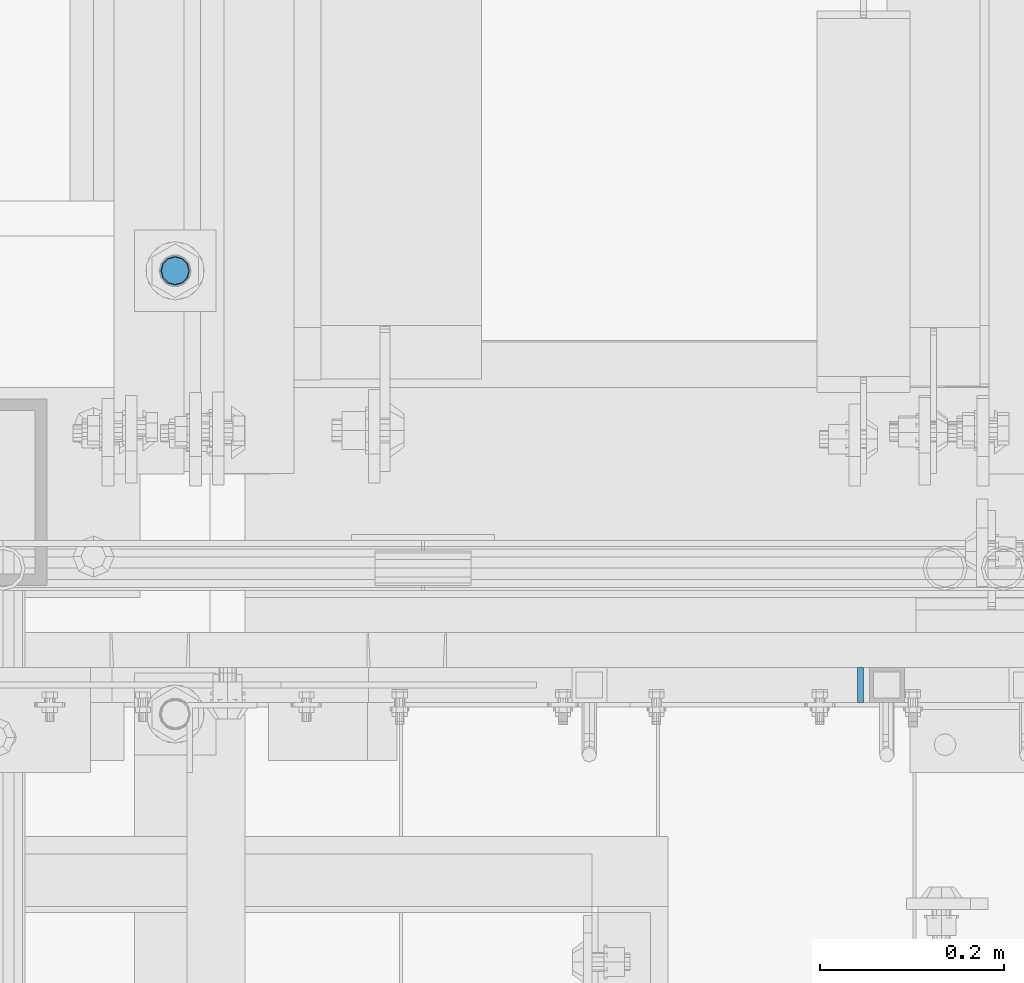
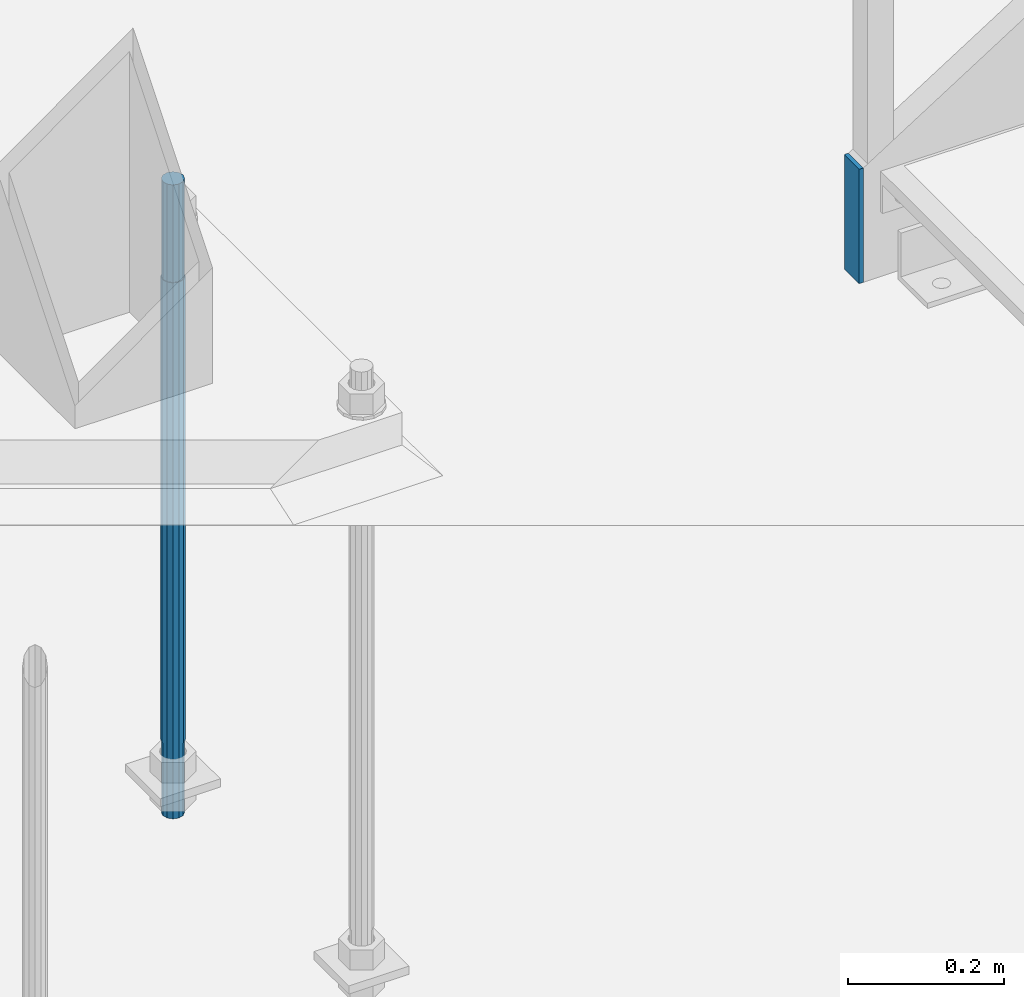
# One storey, part 826 of 1876: 2 columns, 2 elements without a shape of their own.
"""IFC2X3 building model written with IfcOpenShell, lengths in millimetres."""

from ifc_helpers import new_model, si_unit, frame, origin_with_axes, place, context, subcontext, project, spatial, faceted_brep, material, type_object, element, aggregate, save


model = new_model("IFC2X3")

# Units and contexts
model_context = context("Model", 3, precision=1e-05, world=origin_with_axes())
body_context = subcontext(model_context, "Body", "Model", "MODEL_VIEW")
ifc_project = project(units=[si_unit("LENGTHUNIT", "METRE", prefix="MILLI"), si_unit("AREAUNIT", "SQUARE_METRE"), si_unit("VOLUMEUNIT", "CUBIC_METRE"), si_unit("MASSUNIT", "GRAM", prefix="KILO"), si_unit("TIMEUNIT", "SECOND"), si_unit("PLANEANGLEUNIT", "RADIAN"), si_unit("SOLIDANGLEUNIT", "STERADIAN"), si_unit("THERMODYNAMICTEMPERATUREUNIT", "DEGREE_CELSIUS"), si_unit("LUMINOUSINTENSITYUNIT", "LUMEN")], contexts=[model_context])

# Site, building, storey
site_placement = place(None, origin_with_axes())
site = spatial("IfcSite", under=ifc_project, at=site_placement, CompositionType="ELEMENT")
building_placement = place(site_placement, origin_with_axes())
building = spatial("IfcBuilding", under=site, at=building_placement, Name="Undefined", CompositionType="ELEMENT")
storey_placement = place(building_placement, origin_with_axes())
storey = spatial("IfcBuildingStorey", under=building, at=storey_placement, Name="Undefined", CompositionType="ELEMENT", Elevation=0.0)

# Assembly, column
assembly_1_placement = place(storey_placement, origin_with_axes())
assembly_1 = element("IfcElementAssembly", 1, at=assembly_1_placement, inside=storey, Name="STRINGER", AssemblyPlace="NOTDEFINED", PredefinedType="RIGID_FRAME")
ifc_material_1 = material(Name="STEEL/A36")
column_type_1 = type_object("IfcColumnType", PredefinedType="NOTDEFINED")
column_1_placement = place(assembly_1_placement, frame((2714.62500033307, -4781.55000120413, 12.6179379306484), z_axis=(0.0, -1.0, 0.0), x_axis=(0.0, 0.0, 1.0)))
column_1 = element("IfcColumn", 2, at=column_1_placement, type_object=column_type_1, material=ifc_material_1, Name="PLATE", context=body_context, shape_type="Brep", body=[
    faceted_brep([(0.0, 3.17500000000018, -19.0500000000002), (0.0, 3.17500000000018, 19.0499992370605), (178.600949888909, 3.17500000000018, 19.0500000000002), (178.600949888909, 3.17500000000018, -19.0500000000002), (0.0, -3.17500000000018, 19.0499992370605), (178.600949888909, -3.17500000000018, 19.0500000000002), (0.0, -3.17500000000018, -19.0500000000002), (178.600949888909, -3.17500000000018, -19.0500000000002)], [[[0, 1, 2, 3]], [[1, 4, 5, 2]], [[4, 6, 7, 5]], [[6, 0, 3, 7]], [[5, 7, 3, 2]], [[6, 4, 1, 0]]]),
])
aggregate(assembly_1, [column_1])

assembly_2_placement = place(storey_placement, origin_with_axes())
assembly_2 = element("IfcElementAssembly", 3, at=assembly_2_placement, inside=storey, Name="TEMPLATE", AssemblyPlace="NOTDEFINED", PredefinedType="RIGID_FRAME")
ifc_material_2 = material(Name="STEEL/F1554-GR.55")
column_type_2 = type_object("IfcColumnType", PredefinedType="NOTDEFINED")
column_2_placement = place(assembly_2_placement, frame((1968.5, -4330.7, 0.0), z_axis=(-1.0, 0.0, 0.0), x_axis=(0.0, 0.0, -1.0)))
column_2 = element("IfcColumn", 4, at=column_2_placement, type_object=column_type_2, material=ifc_material_2, Name="ANCHOR_BOLTS", context=body_context, shape_type="Brep", body=[
    faceted_brep([(-152.4, -12.9903810567666, 7.5), (-152.4, -7.5, 12.9903810567666), (-152.4, 0.0, 15.0), (-152.4, 7.5, 12.9903810567666), (-152.4, 12.9903810567666, 7.5), (-152.4, 15.0, 0.0), (-152.4, 12.9903810567666, -7.5), (-152.4, 7.5, -12.9903810567666), (-152.4, 0.0, -15.0), (-152.4, -7.5, -12.9903810567666), (-152.4, -12.9903810567666, -7.5), (-152.4, -15.0, 0.0), (0.0, 15.0, 0.0), (0.0, 12.9903810567666, -7.5), (0.0, 7.5, -12.9903810567666), (0.0, 0.0, -15.0), (0.0, -7.5, -12.9903810567666), (0.0, -12.9903810567666, -7.5), (0.0, -15.0, 0.0), (0.0, -12.9903810567666, 7.5), (0.0, -7.5, 12.9903810567666), (0.0, 0.0, 15.0), (0.0, 7.5, 12.9903810567666), (0.0, 12.9903810567666, 7.5), (0.0, -13.7481532850779, 7.9375), (0.0, -7.9375, 13.7481532850798), (0.0, 0.0, 15.875), (0.0, 7.9375, 13.7481532850798), (0.0, 13.7481532850779, 7.9375), (0.0, 15.875, 0.0), (0.0, 13.7481532850779, -7.9375), (0.0, 7.9375, -13.7481532850798), (0.0, 0.0, -15.875), (0.0, -7.9375, -13.7481532850798), (0.0, -13.7481532850779, -7.9375), (0.0, -15.875, 0.0), (723.9, -15.875, 0.0), (723.9, -13.7481532850779, 7.9375), (723.9, -7.9375, 13.7481532850779), (723.9, 0.0, 15.875), (723.9, 7.9375, 13.7481532850779), (723.9, 13.7481532850779, 7.9375), (723.9, 15.875, 0.0), (723.9, 13.7481532850779, -7.9375), (723.9, 7.9375, -13.7481532850779), (723.9, 0.0, -15.875), (723.9, -7.9375, -13.7481532850779), (723.9, -13.7481532850779, -7.9375), (723.9, -7.5, 12.9903810567666), (723.9, 0.0, 15.0), (723.9, 7.5, 12.9903810567666), (723.9, 12.9903810567666, 7.5), (723.9, 15.0, 0.0), (723.9, 12.9903810567666, -7.5), (723.9, 7.5, -12.9903810567666), (723.9, 0.0, -15.0), (723.9, -7.5, -12.9903810567666), (723.9, -12.9903810567666, -7.5), (723.9, -15.0, 0.0), (723.9, -12.9903810567666, 7.5), (838.2, -7.5, -12.9903810567666), (838.2, 0.0, -15.0), (838.2, 7.5, -12.9903810567666), (838.2, 12.9903810567666, -7.5), (838.2, 15.0, 0.0), (838.2, 12.9903810567666, 7.5), (838.2, 7.5, 12.9903810567666), (838.2, 0.0, 15.0), (838.2, -7.5, 12.9903810567666), (838.2, -12.9903810567666, 7.5), (838.2, -15.0, 0.0), (838.2, -12.9903810567666, -7.5)], [[[0, 1, 2, 3, 4, 5, 6, 7, 8, 9, 10, 11]], [[6, 5, 12, 13]], [[7, 6, 13, 14]], [[8, 7, 14, 15]], [[9, 8, 15, 16]], [[10, 9, 16, 17]], [[11, 10, 17, 18]], [[0, 11, 18, 19]], [[1, 0, 19, 20]], [[2, 1, 20, 21]], [[3, 2, 21, 22]], [[4, 3, 22, 23]], [[5, 4, 23, 12]], [[24, 25, 26, 27, 28, 29, 30, 31, 32, 33, 34, 35], [22, 21, 20, 19, 18, 17, 16, 15, 14, 13, 12, 23]], [[24, 35, 36, 37]], [[25, 24, 37, 38]], [[26, 25, 38, 39]], [[27, 26, 39, 40]], [[28, 27, 40, 41]], [[29, 28, 41, 42]], [[30, 29, 42, 43]], [[31, 30, 43, 44]], [[32, 31, 44, 45]], [[33, 32, 45, 46]], [[34, 33, 46, 47]], [[35, 34, 47, 36]], [[46, 45, 44, 43, 42, 41, 40, 39, 38, 37, 36, 47], [48, 49, 50, 51, 52, 53, 54, 55, 56, 57, 58, 59]], [[60, 61, 62, 63, 64, 65, 66, 67, 68, 69, 70, 71]], [[68, 67, 49, 48]], [[69, 68, 48, 59]], [[70, 69, 59, 58]], [[71, 70, 58, 57]], [[60, 71, 57, 56]], [[61, 60, 56, 55]], [[62, 61, 55, 54]], [[63, 62, 54, 53]], [[64, 63, 53, 52]], [[65, 64, 52, 51]], [[66, 65, 51, 50]], [[67, 66, 50, 49]]]),
])
aggregate(assembly_2, [column_2])

save(model, "model.ifc")
